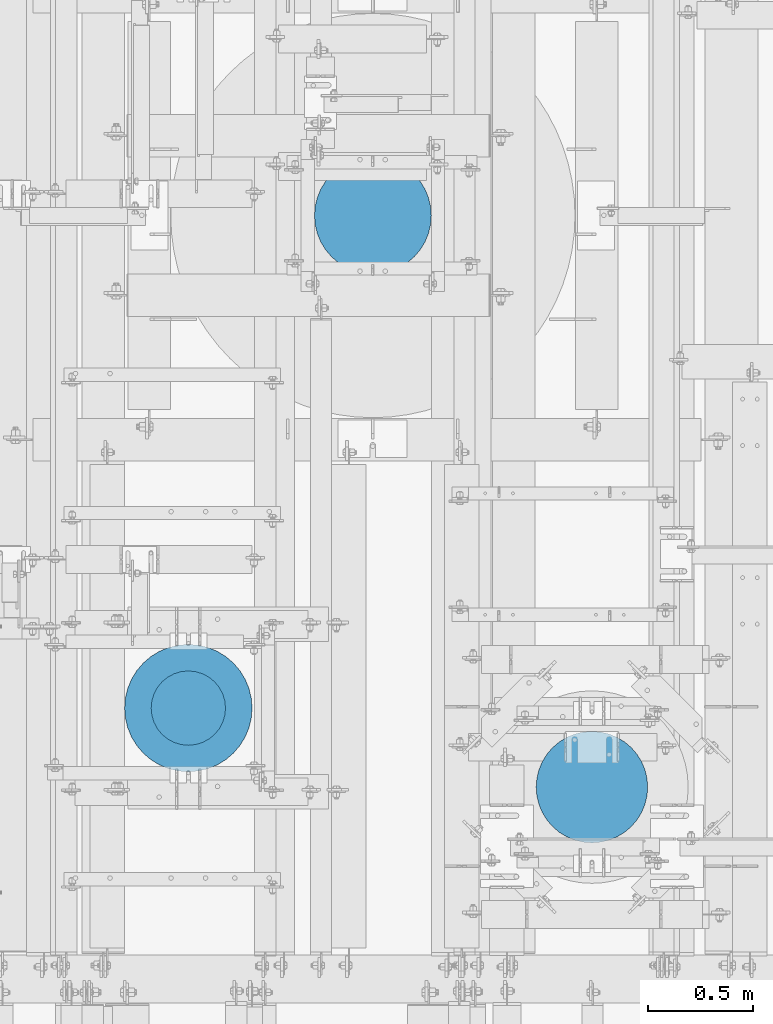
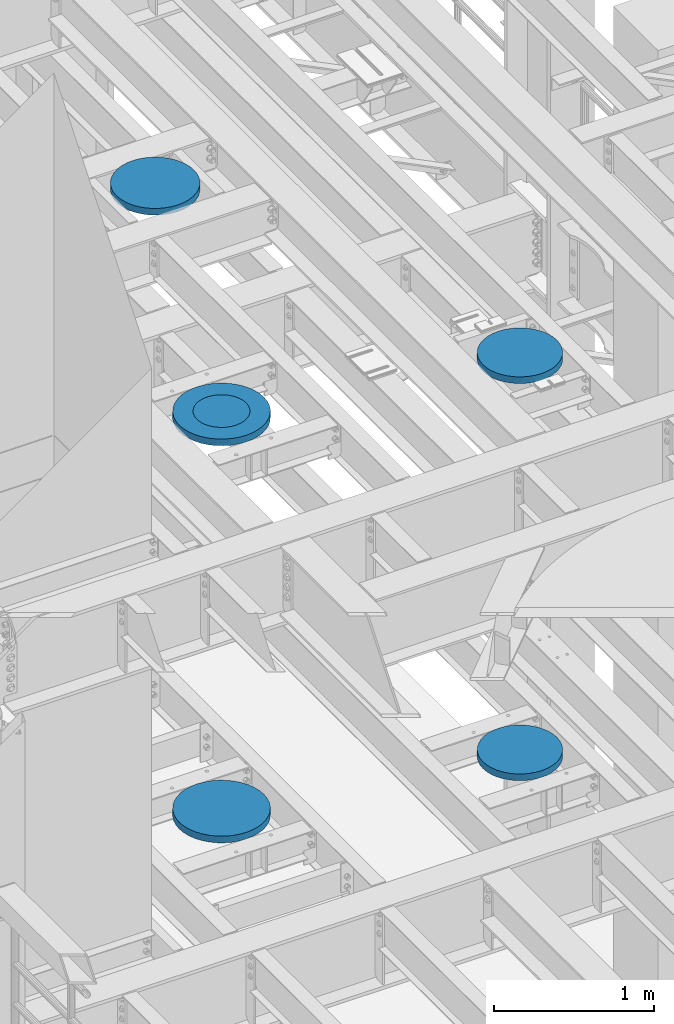
# One storey, part 840 of 1876: 6 columns, 6 elements without a shape of their own.
"""IFC2X3 building model written with IfcOpenShell, lengths in millimetres."""

import ifcopenshell
import ifcopenshell.guid

model = None  # the IFC model being written
_history = None  # IfcOwnerHistory: only IFC2X3 demands one
_inside = {}  # id of a spatial element -> (the spatial element, [elements in it])
_under = {}  # id of a project, library or spatial element -> (it, [spatial elements below it])
_declared = {}  # id of a project -> (the project, [libraries it declares])
_typed = {}  # id of a type object -> (the type object, [elements of that type])
_made_of = {}  # id of a material, layer set ... -> (it, [elements and type objects made of it])


def new_model(schema):
    """Start an empty IFC model of exactly this schema.

    Asked for "IFC4X3", IfcOpenShell would pick the latest addendum, in which some entities
    have other attributes; the version numbers below select the first issue.
    IFC2X3 requires an IfcOwnerHistory on every rooted entity: one is made here for all.
    """
    global model, _history
    if schema == "IFC4X3":
        model = ifcopenshell.file(schema_version=(4, 3, 0, 0))
    else:
        model = ifcopenshell.file(schema=schema)
    _inside.clear()
    _under.clear()
    _declared.clear()
    _typed.clear()
    _made_of.clear()
    _history = None
    if model.schema == "IFC2X3":
        org = make("IfcOrganization", Name="unknown")
        user = make(
            "IfcPersonAndOrganization",
            ThePerson=make("IfcPerson", FamilyName="unknown"),
            TheOrganization=org,
        )
        app = make(
            "IfcApplication",
            ApplicationDeveloper=org,
            Version="unknown",
            ApplicationFullName="unknown",
            ApplicationIdentifier="unknown",
        )
        _history = make(
            "IfcOwnerHistory",
            OwningUser=user,
            OwningApplication=app,
            ChangeAction="ADDED",
            CreationDate=0,
        )
    return model


def make(cls, **values):
    """One entity of the class cls with the attributes given. An attribute that is None is left unset."""
    return model.create_entity(
        cls, **{name: value for name, value in values.items() if value is not None}
    )


def rooted(cls, **values):
    """An entity with a GlobalId (a new one), such as an element, a storey or a relation."""
    return make(cls, GlobalId=ifcopenshell.guid.new(), OwnerHistory=_history, **values)


def si_unit(unit_type, name, prefix=None):
    """IfcSIUnit, for example si_unit("LENGTHUNIT", "METRE", prefix="MILLI")."""
    return make("IfcSIUnit", UnitType=unit_type, Prefix=prefix, Name=name)


def assignment(units):
    """IfcUnitAssignment: the units of a project."""
    return None if units is None else make("IfcUnitAssignment", Units=units)


def point(xyz):
    """IfcCartesianPoint."""
    return None if xyz is None else make("IfcCartesianPoint", Coordinates=xyz)


def direction(xyz):
    """IfcDirection."""
    return None if xyz is None else make("IfcDirection", DirectionRatios=xyz)


def frame(location, z_axis=None, x_axis=None):
    """IfcAxis2Placement3D, a coordinate frame: its origin and axes. An axis left out is left unset."""
    return make(
        "IfcAxis2Placement3D",
        Location=point(location),
        Axis=direction(z_axis),
        RefDirection=direction(x_axis),
    )


def origin_with_axes():
    """The frame at (0, 0, 0) with the z axis (0, 0, 1) and the x axis (1, 0, 0) written out."""
    return frame((0.0, 0.0, 0.0), z_axis=(0.0, 0.0, 1.0), x_axis=(1.0, 0.0, 0.0))


def place(relative_to, where):
    """IfcLocalPlacement: puts the frame where relative to a parent placement (None: the world)."""
    return make(
        "IfcLocalPlacement", PlacementRelTo=relative_to, RelativePlacement=where
    )


def context(
    kind, dimensions, precision=None, world=None, true_north=None, identifier=None
):
    """IfcGeometricRepresentationContext, for example the 3D "Model" context."""
    return make(
        "IfcGeometricRepresentationContext",
        ContextIdentifier=identifier,
        ContextType=kind,
        CoordinateSpaceDimension=dimensions,
        Precision=precision,
        WorldCoordinateSystem=world,
        TrueNorth=true_north,
    )


def subcontext(parent, identifier, kind, view, scale=None):
    """IfcGeometricRepresentationSubContext, for example "Body" below "Model"."""
    return make(
        "IfcGeometricRepresentationSubContext",
        ContextIdentifier=identifier,
        ContextType=kind,
        ParentContext=parent,
        TargetScale=scale,
        TargetView=view,
    )


def project(units=None, contexts=None):
    """IfcProject with its units and contexts."""
    return rooted(
        "IfcProject",
        Name="project",
        RepresentationContexts=contexts,
        UnitsInContext=assignment(units),
    )


def spatial(cls, under=None, at=None, **own):
    """A site, building, storey or space (cls), placed at a placement, below another one or the project."""
    s = rooted(cls, ObjectPlacement=at, **own)
    if under is not None:
        _under.setdefault(under.id(), (under, []))[1].append(s)
    return s


def faces_of(points, faces, orient=None, outer=None):
    """IfcFace entities. A face is a list of loops; a loop is a list of indices into points, from 0.

    orient and outer hold one flag for each loop. By default every Orientation is true, the
    first loop of a face is its IfcFaceOuterBound and the others are IfcFaceBound.
    """
    made = []
    for i, loops in enumerate(faces):
        bounds = []
        for j, loop in enumerate(loops):
            is_outer = j == 0 if outer is None else outer[i][j]
            bounds.append(
                make(
                    "IfcFaceOuterBound" if is_outer else "IfcFaceBound",
                    Bound=make("IfcPolyLoop", Polygon=[points[k] for k in loop]),
                    Orientation=True if orient is None else orient[i][j],
                )
            )
        made.append(make("IfcFace", Bounds=bounds))
    return made


def faceted_brep(points, faces, orient=None, outer=None, voids=None):
    """IfcFacetedBrep: a solid bounded by flat faces; with voids (closed shells), ...WithVoids."""
    shared = [point(p) for p in points]
    hull = make("IfcClosedShell", CfsFaces=faces_of(shared, faces, orient, outer))
    if voids is None:
        return make("IfcFacetedBrep", Outer=hull)
    return make(
        "IfcFacetedBrepWithVoids",
        Outer=hull,
        Voids=[
            make(cls, CfsFaces=faces_of(shared, fs, o, b)) for cls, fs, o, b in voids
        ],
    )


def shape(context_of_items, identifier, shape_type, items):
    """IfcShapeRepresentation: the items that make up one representation, for example the "Body"."""
    return make(
        "IfcShapeRepresentation",
        ContextOfItems=context_of_items,
        RepresentationIdentifier=identifier,
        RepresentationType=shape_type,
        Items=items,
    )


def material(Name=None, Category=None):
    """IfcMaterial."""
    return make("IfcMaterial", Name=Name, Category=Category)


def made_of(thing, what):
    """Note that an element or type object is made of a material, layer set ...; save() writes the relation."""
    if what is not None:
        _made_of.setdefault(what.id(), (what, []))[1].append(thing)
    return thing


def type_object(cls, material=None, **own):
    """A type object (cls), such as IfcWallType, which elements share."""
    return made_of(rooted(cls, **own), material)


def element(
    cls,
    number,
    at=None,
    inside=None,
    cuts=None,
    type_object=None,
    material=None,
    context=None,
    identifier="Body",
    shape_type=None,
    held_by="IfcProductDefinitionShape",
    body=None,
    shapes=None,
    **own,
):
    """One element of the class cls, such as IfcWall. Its Tag is "e" and its number.

    at: its placement. inside: the storey or other place that contains it. cuts: it is an
    opening in that element (IfcRelVoidsElement). A single representation is given by context,
    identifier, shape_type and body (its items); several are given by shapes. held_by: the class
    of the entity that holds the representations. save() writes the other relations.
    """
    e = rooted(cls, Tag="e%d" % number, ObjectPlacement=at, **own)
    if body is not None:
        shapes = [shape(context, identifier, shape_type, body)]
    if shapes is not None:
        e.Representation = make(held_by, Representations=shapes)
    if inside is not None:
        _inside.setdefault(inside.id(), (inside, []))[1].append(e)
    if cuts is not None:
        rooted(
            "IfcRelVoidsElement", RelatingBuildingElement=cuts, RelatedOpeningElement=e
        )
    if type_object is not None:
        _typed.setdefault(type_object.id(), (type_object, []))[1].append(e)
    return made_of(e, material)


def aggregate(whole, parts):
    """IfcRelAggregates: a whole, such as a stair, and the parts it consists of."""
    return rooted("IfcRelAggregates", RelatingObject=whole, RelatedObjects=parts)


def save(model, path):
    """Write the relations noted so far, then the file.

    IfcRelAggregates (storeys below a building ...), IfcRelContainedInSpatialStructure (elements
    in a storey), IfcRelDefinesByType, IfcRelAssociatesMaterial and IfcRelDeclares: one each for
    every whole, place, type object, material and project.
    """
    for whole, parts in _under.values():
        aggregate(whole, parts)
    for where, things in _inside.values():
        rooted(
            "IfcRelContainedInSpatialStructure",
            RelatedElements=things,
            RelatingStructure=where,
        )
    for kind, things in _typed.values():
        rooted("IfcRelDefinesByType", RelatedObjects=things, RelatingType=kind)
    for what, things in _made_of.values():
        rooted("IfcRelAssociatesMaterial", RelatedObjects=things, RelatingMaterial=what)
    for by, libraries in _declared.values():
        rooted("IfcRelDeclares", RelatingContext=by, RelatedDefinitions=libraries)
    model.write(path)


model = new_model("IFC2X3")

# Units and contexts
model_context = context("Model", 3, precision=1e-05, world=origin_with_axes())
body_context = subcontext(model_context, "Body", "Model", "MODEL_VIEW")
ifc_project = project(units=[si_unit("LENGTHUNIT", "METRE", prefix="MILLI"), si_unit("AREAUNIT", "SQUARE_METRE"), si_unit("VOLUMEUNIT", "CUBIC_METRE"), si_unit("MASSUNIT", "GRAM", prefix="KILO"), si_unit("TIMEUNIT", "SECOND"), si_unit("PLANEANGLEUNIT", "RADIAN"), si_unit("SOLIDANGLEUNIT", "STERADIAN"), si_unit("THERMODYNAMICTEMPERATUREUNIT", "DEGREE_CELSIUS"), si_unit("LUMINOUSINTENSITYUNIT", "LUMEN")], contexts=[model_context])

# Site, building, storey
site_placement = place(None, origin_with_axes())
site = spatial("IfcSite", under=ifc_project, at=site_placement, CompositionType="ELEMENT")
building_placement = place(site_placement, origin_with_axes())
building = spatial("IfcBuilding", under=site, at=building_placement, Name="Undefined", CompositionType="ELEMENT")
storey_placement = place(building_placement, origin_with_axes())
storey = spatial("IfcBuildingStorey", under=building, at=storey_placement, Name="Undefined", CompositionType="ELEMENT", Elevation=0.0)

# Assembly, column
assembly_1_placement = place(storey_placement, origin_with_axes())
assembly_1 = element("IfcElementAssembly", 1, at=assembly_1_placement, inside=storey, Name="COLUMN", AssemblyPlace="NOTDEFINED", PredefinedType="REINFORCEMENT_UNIT")
ifc_material = material(Name="CONCRETE/3000")
column_type_1 = type_object("IfcColumnType", PredefinedType="NOTDEFINED")
column_1_placement = place(assembly_1_placement, frame((2489.2, 2819.4, 8128.0), z_axis=(-1.0, 0.0, 0.0), x_axis=(0.0, 0.0, 1.0)))
column_1 = element("IfcColumn", 2, at=column_1_placement, type_object=column_type_1, material=ifc_material, Name="COLUMN", context=body_context, shape_type="Brep", body=[
    faceted_brep([(0.0, -177.8, 0.0), (0.0, -174.383622855695, -34.6870592544674), (50.7999999999993, -174.383622855695, -34.6870592544674), (50.7999999999993, -177.8, 0.0), (0.0, -164.265780880507, -68.0411142745133), (50.7999999999993, -164.265780880507, -68.0411142745133), (0.0, -147.835297067392, -98.7803874308856), (50.7999999999993, -147.835297067392, -98.7803874308856), (0.0, -125.723585694968, -125.723585694968), (50.7999999999993, -125.723585694968, -125.723585694968), (0.0, -98.7803874308856, -147.835297067392), (50.7999999999993, -98.7803874308856, -147.835297067392), (0.0, -68.0411142745133, -164.265780880507), (50.7999999999993, -68.0411142745133, -164.265780880507), (0.0, -34.6870592544674, -174.383622855695), (50.7999999999993, -34.6870592544674, -174.383622855695), (0.0, 0.0, -177.800003051758), (50.7999999999993, 0.0, -177.8), (0.0, 34.6870592544674, -174.383622855695), (50.7999999999993, 34.6870592544674, -174.383622855695), (0.0, 68.0411142745133, -164.265780880507), (50.7999999999993, 68.0411142745133, -164.265780880507), (0.0, 98.7803874308856, -147.835297067392), (50.7999999999993, 98.7803874308856, -147.835297067392), (0.0, 125.723585694968, -125.723585694968), (50.7999999999993, 125.723585694968, -125.723585694968), (0.0, 147.835297067392, -98.7803874308856), (50.7999999999993, 147.835297067392, -98.7803874308856), (0.0, 164.265780880507, -68.0411142745133), (50.7999999999993, 164.265780880507, -68.0411142745133), (0.0, 174.383622855694, -34.6870592544674), (50.7999999999993, 174.383622855694, -34.6870592544674), (0.0, 177.8, 0.0), (50.7999999999993, 177.8, 0.0), (0.0, 174.383622855694, 34.6870592544674), (50.7999999999993, 174.383622855694, 34.6870592544674), (0.0, 164.265780880507, 68.0411142745133), (50.7999999999993, 164.265780880507, 68.0411142745133), (0.0, 147.835297067392, 98.7803874308856), (50.7999999999993, 147.835297067392, 98.7803874308856), (0.0, 125.723585694968, 125.723585694968), (50.7999999999993, 125.723585694968, 125.723585694968), (0.0, 98.7803874308856, 147.835297067392), (50.7999999999993, 98.7803874308856, 147.835297067392), (0.0, 68.0411142745133, 164.265780880507), (50.7999999999993, 68.0411142745133, 164.265780880507), (0.0, 34.6870592544674, 174.383622855695), (50.7999999999993, 34.6870592544674, 174.383622855695), (0.0, 0.0, 177.800003051758), (50.7999999999993, 0.0, 177.8), (0.0, -34.6870592544674, 174.383622855695), (50.7999999999993, -34.6870592544674, 174.383622855695), (0.0, -68.0411142745133, 164.265780880507), (50.7999999999993, -68.0411142745133, 164.265780880507), (0.0, -98.7803874308856, 147.835297067392), (50.7999999999993, -98.7803874308856, 147.835297067392), (0.0, -125.723585694968, 125.723585694968), (50.7999999999993, -125.723585694968, 125.723585694968), (0.0, -147.835297067392, 98.7803874308856), (50.7999999999993, -147.835297067392, 98.7803874308856), (0.0, -164.265780880507, 68.0411142745133), (50.7999999999993, -164.265780880507, 68.0411142745133), (0.0, -174.383622855695, 34.6870592544674), (50.7999999999993, -174.383622855695, 34.6870592544674)], [[[0, 1, 2, 3]], [[1, 4, 5, 2]], [[4, 6, 7, 5]], [[6, 8, 9, 7]], [[8, 10, 11, 9]], [[10, 12, 13, 11]], [[12, 14, 15, 13]], [[14, 16, 17, 15]], [[16, 18, 19, 17]], [[18, 20, 21, 19]], [[20, 22, 23, 21]], [[22, 24, 25, 23]], [[24, 26, 27, 25]], [[26, 28, 29, 27]], [[28, 30, 31, 29]], [[30, 32, 33, 31]], [[32, 34, 35, 33]], [[34, 36, 37, 35]], [[36, 38, 39, 37]], [[38, 40, 41, 39]], [[40, 42, 43, 41]], [[42, 44, 45, 43]], [[44, 46, 47, 45]], [[46, 48, 49, 47]], [[48, 50, 51, 49]], [[50, 52, 53, 51]], [[52, 54, 55, 53]], [[54, 56, 57, 55]], [[56, 58, 59, 57]], [[58, 60, 61, 59]], [[60, 62, 63, 61]], [[62, 0, 3, 63]], [[5, 7, 9, 11, 13, 15, 17, 19, 21, 23, 25, 27, 29, 31, 33, 35, 37, 39, 41, 43, 45, 47, 49, 51, 53, 55, 57, 59, 61, 63, 3, 2]], [[62, 60, 58, 56, 54, 52, 50, 48, 46, 44, 42, 40, 38, 36, 34, 32, 30, 28, 26, 24, 22, 20, 18, 16, 14, 12, 10, 8, 6, 4, 1, 0]]]),
])
aggregate(assembly_1, [column_1])

assembly_2_placement = place(storey_placement, origin_with_axes())
assembly_2 = element("IfcElementAssembly", 3, at=assembly_2_placement, inside=storey, Name="COLUMN", AssemblyPlace="NOTDEFINED", PredefinedType="REINFORCEMENT_UNIT")
column_type_2 = type_object("IfcColumnType", PredefinedType="NOTDEFINED")
column_2_placement = place(assembly_2_placement, frame((2489.2, 2819.4, 8128.0), z_axis=(-1.0, 0.0, 0.0), x_axis=(0.0, 0.0, 1.0)))
column_2 = element("IfcColumn", 4, at=column_2_placement, type_object=column_type_2, material=ifc_material, Name="COLUMN", context=body_context, shape_type="Brep", body=[
    faceted_brep([(0.0, -304.8, 0.0), (0.0, -301.047406213398, -47.6812249442623), (50.7999999999993, -301.047406213398, -47.6812249442623), (50.7999999999993, -304.8, 0.0), (0.0, -289.882026166763, -94.1883798854842), (50.7999999999993, -289.882026166763, -94.1883798854842), (0.0, -271.578788572614, -138.376304320614), (50.7999999999993, -271.578788572614, -138.376304320614), (0.0, -246.588379885484, -179.156944898746), (50.7999999999993, -246.588379885484, -179.156944898746), (0.0, -215.52614690566, -215.52614690566), (50.7999999999993, -215.52614690566, -215.52614690566), (0.0, -179.156944898746, -246.588379885484), (50.7999999999993, -179.156944898746, -246.588379885484), (0.0, -138.376304320614, -271.578788572614), (50.7999999999993, -138.376304320614, -271.578788572614), (0.0, -94.1883798854838, -289.882026166763), (50.7999999999993, -94.1883798854838, -289.882026166763), (0.0, -47.6812249442623, -301.047406213398), (50.7999999999993, -47.6812249442623, -301.047406213398), (0.0, 0.0, -304.8), (50.7999999999993, 0.0, -304.8), (0.0, 47.6812249442623, -301.047406213398), (50.7999999999993, 47.6812249442623, -301.047406213398), (0.0, 94.1883798854842, -289.882026166763), (50.7999999999993, 94.1883798854842, -289.882026166763), (0.0, 138.376304320614, -271.578788572614), (50.7999999999993, 138.376304320614, -271.578788572614), (0.0, 179.156944898746, -246.588379885484), (50.7999999999993, 179.156944898746, -246.588379885484), (0.0, 215.52614690566, -215.52614690566), (50.7999999999993, 215.52614690566, -215.52614690566), (0.0, 246.588379885484, -179.156944898746), (50.7999999999993, 246.588379885484, -179.156944898746), (0.0, 271.578788572614, -138.376304320614), (50.7999999999993, 271.578788572614, -138.376304320614), (0.0, 289.882026166763, -94.1883798854838), (50.7999999999993, 289.882026166763, -94.1883798854838), (0.0, 301.047406213398, -47.6812249442623), (50.7999999999993, 301.047406213398, -47.6812249442623), (0.0, 304.8, 0.0), (50.7999999999993, 304.8, 0.0), (0.0, 301.047406213398, 47.6812249442623), (50.7999999999993, 301.047406213398, 47.6812249442623), (0.0, 289.882026166763, 94.1883798854842), (50.7999999999993, 289.882026166763, 94.1883798854842), (0.0, 271.578788572614, 138.376304320614), (50.7999999999993, 271.578788572614, 138.376304320614), (0.0, 246.588379885484, 179.156944898746), (50.7999999999993, 246.588379885484, 179.156944898746), (0.0, 215.52614690566, 215.52614690566), (50.7999999999993, 215.52614690566, 215.52614690566), (0.0, 179.156944898746, 246.588379885484), (50.7999999999993, 179.156944898746, 246.588379885484), (0.0, 138.376304320614, 271.578788572614), (50.7999999999993, 138.376304320614, 271.578788572614), (0.0, 94.1883798854838, 289.882026166763), (50.7999999999993, 94.1883798854838, 289.882026166763), (0.0, 47.6812249442623, 301.047406213398), (50.7999999999993, 47.6812249442623, 301.047406213398), (0.0, 0.0, 304.8), (50.7999999999993, 0.0, 304.8), (0.0, -47.6812249442623, 301.047406213398), (50.7999999999993, -47.6812249442623, 301.047406213398), (0.0, -94.1883798854838, 289.882026166763), (50.7999999999993, -94.1883798854838, 289.882026166763), (0.0, -138.376304320614, 271.578788572614), (50.7999999999993, -138.376304320614, 271.578788572614), (0.0, -179.156944898746, 246.588379885484), (50.7999999999993, -179.156944898746, 246.588379885484), (0.0, -215.52614690566, 215.52614690566), (50.7999999999993, -215.52614690566, 215.52614690566), (0.0, -246.588379885484, 179.156944898746), (50.7999999999993, -246.588379885484, 179.156944898746), (0.0, -271.578788572614, 138.376304320614), (50.7999999999993, -271.578788572614, 138.376304320614), (0.0, -289.882026166763, 94.1883798854838), (50.7999999999993, -289.882026166763, 94.1883798854838), (0.0, -301.047406213398, 47.6812249442623), (50.7999999999993, -301.047406213398, 47.6812249442623)], [[[0, 1, 2, 3]], [[1, 4, 5, 2]], [[4, 6, 7, 5]], [[6, 8, 9, 7]], [[8, 10, 11, 9]], [[10, 12, 13, 11]], [[12, 14, 15, 13]], [[14, 16, 17, 15]], [[16, 18, 19, 17]], [[18, 20, 21, 19]], [[20, 22, 23, 21]], [[22, 24, 25, 23]], [[24, 26, 27, 25]], [[26, 28, 29, 27]], [[28, 30, 31, 29]], [[30, 32, 33, 31]], [[32, 34, 35, 33]], [[34, 36, 37, 35]], [[36, 38, 39, 37]], [[38, 40, 41, 39]], [[40, 42, 43, 41]], [[42, 44, 45, 43]], [[44, 46, 47, 45]], [[46, 48, 49, 47]], [[48, 50, 51, 49]], [[50, 52, 53, 51]], [[52, 54, 55, 53]], [[54, 56, 57, 55]], [[56, 58, 59, 57]], [[58, 60, 61, 59]], [[60, 62, 63, 61]], [[62, 64, 65, 63]], [[64, 66, 67, 65]], [[66, 68, 69, 67]], [[68, 70, 71, 69]], [[70, 72, 73, 71]], [[72, 74, 75, 73]], [[74, 76, 77, 75]], [[76, 78, 79, 77]], [[78, 0, 3, 79]], [[5, 7, 9, 11, 13, 15, 17, 19, 21, 23, 25, 27, 29, 31, 33, 35, 37, 39, 41, 43, 45, 47, 49, 51, 53, 55, 57, 59, 61, 63, 65, 67, 69, 71, 73, 75, 77, 79, 3, 2]], [[78, 76, 74, 72, 70, 68, 66, 64, 62, 60, 58, 56, 54, 52, 50, 48, 46, 44, 42, 40, 38, 36, 34, 32, 30, 28, 26, 24, 22, 20, 18, 16, 14, 12, 10, 8, 6, 4, 1, 0]]]),
])
aggregate(assembly_2, [column_2])

assembly_3_placement = place(storey_placement, origin_with_axes())
assembly_3 = element("IfcElementAssembly", 5, at=assembly_3_placement, inside=storey, Name="COLUMN", AssemblyPlace="NOTDEFINED", PredefinedType="REINFORCEMENT_UNIT")
column_3_placement = place(assembly_3_placement, frame((2489.2, 2819.4, 5105.4), z_axis=(-1.0, 0.0, 0.0), x_axis=(0.0, 0.0, 1.0)))
column_3 = element("IfcColumn", 6, at=column_3_placement, type_object=column_type_2, material=ifc_material, Name="COLUMN", context=body_context, shape_type="Brep", body=[
    faceted_brep([(0.0, -304.8, 0.0), (0.0, -301.047406213398, -47.6812249442623), (50.7999999999993, -301.047406213398, -47.6812249442623), (50.7999999999993, -304.8, 0.0), (0.0, -289.882026166763, -94.1883798854842), (50.7999999999993, -289.882026166763, -94.1883798854842), (0.0, -271.578788572614, -138.376304320614), (50.7999999999993, -271.578788572614, -138.376304320614), (0.0, -246.588379885484, -179.156944898746), (50.7999999999993, -246.588379885484, -179.156944898746), (0.0, -215.52614690566, -215.52614690566), (50.7999999999993, -215.52614690566, -215.52614690566), (0.0, -179.156944898746, -246.588379885484), (50.7999999999993, -179.156944898746, -246.588379885484), (0.0, -138.376304320614, -271.578788572614), (50.7999999999993, -138.376304320614, -271.578788572614), (0.0, -94.1883798854838, -289.882026166763), (50.7999999999993, -94.1883798854838, -289.882026166763), (0.0, -47.6812249442623, -301.047406213398), (50.7999999999993, -47.6812249442623, -301.047406213398), (0.0, 0.0, -304.8), (50.7999999999993, 0.0, -304.8), (0.0, 47.6812249442623, -301.047406213398), (50.7999999999993, 47.6812249442623, -301.047406213398), (0.0, 94.1883798854842, -289.882026166763), (50.7999999999993, 94.1883798854842, -289.882026166763), (0.0, 138.376304320614, -271.578788572614), (50.7999999999993, 138.376304320614, -271.578788572614), (0.0, 179.156944898746, -246.588379885484), (50.7999999999993, 179.156944898746, -246.588379885484), (0.0, 215.52614690566, -215.52614690566), (50.7999999999993, 215.52614690566, -215.52614690566), (0.0, 246.588379885484, -179.156944898746), (50.7999999999993, 246.588379885484, -179.156944898746), (0.0, 271.578788572614, -138.376304320614), (50.7999999999993, 271.578788572614, -138.376304320614), (0.0, 289.882026166763, -94.1883798854838), (50.7999999999993, 289.882026166763, -94.1883798854838), (0.0, 301.047406213398, -47.6812249442623), (50.7999999999993, 301.047406213398, -47.6812249442623), (0.0, 304.8, 0.0), (50.7999999999993, 304.8, 0.0), (0.0, 301.047406213398, 47.6812249442623), (50.7999999999993, 301.047406213398, 47.6812249442623), (0.0, 289.882026166763, 94.1883798854842), (50.7999999999993, 289.882026166763, 94.1883798854842), (0.0, 271.578788572614, 138.376304320614), (50.7999999999993, 271.578788572614, 138.376304320614), (0.0, 246.588379885484, 179.156944898746), (50.7999999999993, 246.588379885484, 179.156944898746), (0.0, 215.52614690566, 215.52614690566), (50.7999999999993, 215.52614690566, 215.52614690566), (0.0, 179.156944898746, 246.588379885484), (50.7999999999993, 179.156944898746, 246.588379885484), (0.0, 138.376304320614, 271.578788572614), (50.7999999999993, 138.376304320614, 271.578788572614), (0.0, 94.1883798854838, 289.882026166763), (50.7999999999993, 94.1883798854838, 289.882026166763), (0.0, 47.6812249442623, 301.047406213398), (50.7999999999993, 47.6812249442623, 301.047406213398), (0.0, 0.0, 304.8), (50.7999999999993, 0.0, 304.8), (0.0, -47.6812249442623, 301.047406213398), (50.7999999999993, -47.6812249442623, 301.047406213398), (0.0, -94.1883798854838, 289.882026166763), (50.7999999999993, -94.1883798854838, 289.882026166763), (0.0, -138.376304320614, 271.578788572614), (50.7999999999993, -138.376304320614, 271.578788572614), (0.0, -179.156944898746, 246.588379885484), (50.7999999999993, -179.156944898746, 246.588379885484), (0.0, -215.52614690566, 215.52614690566), (50.7999999999993, -215.52614690566, 215.52614690566), (0.0, -246.588379885484, 179.156944898746), (50.7999999999993, -246.588379885484, 179.156944898746), (0.0, -271.578788572614, 138.376304320614), (50.7999999999993, -271.578788572614, 138.376304320614), (0.0, -289.882026166763, 94.1883798854838), (50.7999999999993, -289.882026166763, 94.1883798854838), (0.0, -301.047406213398, 47.6812249442623), (50.7999999999993, -301.047406213398, 47.6812249442623)], [[[0, 1, 2, 3]], [[1, 4, 5, 2]], [[4, 6, 7, 5]], [[6, 8, 9, 7]], [[8, 10, 11, 9]], [[10, 12, 13, 11]], [[12, 14, 15, 13]], [[14, 16, 17, 15]], [[16, 18, 19, 17]], [[18, 20, 21, 19]], [[20, 22, 23, 21]], [[22, 24, 25, 23]], [[24, 26, 27, 25]], [[26, 28, 29, 27]], [[28, 30, 31, 29]], [[30, 32, 33, 31]], [[32, 34, 35, 33]], [[34, 36, 37, 35]], [[36, 38, 39, 37]], [[38, 40, 41, 39]], [[40, 42, 43, 41]], [[42, 44, 45, 43]], [[44, 46, 47, 45]], [[46, 48, 49, 47]], [[48, 50, 51, 49]], [[50, 52, 53, 51]], [[52, 54, 55, 53]], [[54, 56, 57, 55]], [[56, 58, 59, 57]], [[58, 60, 61, 59]], [[60, 62, 63, 61]], [[62, 64, 65, 63]], [[64, 66, 67, 65]], [[66, 68, 69, 67]], [[68, 70, 71, 69]], [[70, 72, 73, 71]], [[72, 74, 75, 73]], [[74, 76, 77, 75]], [[76, 78, 79, 77]], [[78, 0, 3, 79]], [[5, 7, 9, 11, 13, 15, 17, 19, 21, 23, 25, 27, 29, 31, 33, 35, 37, 39, 41, 43, 45, 47, 49, 51, 53, 55, 57, 59, 61, 63, 65, 67, 69, 71, 73, 75, 77, 79, 3, 2]], [[78, 76, 74, 72, 70, 68, 66, 64, 62, 60, 58, 56, 54, 52, 50, 48, 46, 44, 42, 40, 38, 36, 34, 32, 30, 28, 26, 24, 22, 20, 18, 16, 14, 12, 10, 8, 6, 4, 1, 0]]]),
])
aggregate(assembly_3, [column_3])

assembly_4_placement = place(storey_placement, origin_with_axes())
assembly_4 = element("IfcElementAssembly", 7, at=assembly_4_placement, inside=storey, Name="COLUMN", AssemblyPlace="NOTDEFINED", PredefinedType="REINFORCEMENT_UNIT")
column_type_3 = type_object("IfcColumnType", PredefinedType="NOTDEFINED")
column_4_placement = place(assembly_4_placement, frame((3371.85, 5175.25, 8128.0), z_axis=(-1.0, 0.0, 0.0), x_axis=(0.0, 0.0, 1.0)))
column_4 = element("IfcColumn", 8, at=column_4_placement, type_object=column_type_3, material=ifc_material, Name="COLUMN", context=body_context, shape_type="Brep", body=[
    faceted_brep([(0.0, -279.4, 0.0), (0.0, -275.960122362281, -43.7077895322406), (50.7999999999993, -275.960122362281, -43.7077895322406), (50.7999999999993, -279.4, 0.0), (0.0, -265.725190652865, -86.3393482283603), (50.7999999999993, -265.725190652865, -86.3393482283603), (0.0, -248.947222858231, -126.844945627229), (50.7999999999993, -248.947222858231, -126.844945627229), (0.0, -226.03934822836, -164.227199490517), (50.7999999999993, -226.03934822836, -164.227199490517), (0.0, -197.565634663521, -197.565634663521), (50.7999999999993, -197.565634663521, -197.565634663521), (0.0, -164.227199490517, -226.03934822836), (50.7999999999993, -164.227199490517, -226.03934822836), (0.0, -126.84494562723, -248.94722285823), (50.7999999999993, -126.84494562723, -248.94722285823), (0.0, -86.3393482283609, -265.725190652866), (50.7999999999993, -86.3393482283609, -265.725190652866), (0.0, -43.70778953224, -275.960122362281), (50.7999999999993, -43.70778953224, -275.960122362281), (0.0, 0.0, -279.4), (50.7999999999993, 0.0, -279.4), (0.0, 43.70778953224, -275.960122362281), (50.7999999999993, 43.70778953224, -275.960122362281), (0.0, 86.3393482283609, -265.725190652866), (50.7999999999993, 86.3393482283609, -265.725190652866), (0.0, 126.84494562723, -248.94722285823), (50.7999999999993, 126.84494562723, -248.94722285823), (0.0, 164.227199490517, -226.03934822836), (50.7999999999993, 164.227199490517, -226.03934822836), (0.0, 197.565634663521, -197.565634663521), (50.7999999999993, 197.565634663521, -197.565634663521), (0.0, 226.03934822836, -164.227199490517), (50.7999999999993, 226.03934822836, -164.227199490517), (0.0, 248.947222858231, -126.844945627229), (50.7999999999993, 248.947222858231, -126.844945627229), (0.0, 265.725190652865, -86.3393482283602), (50.7999999999993, 265.725190652865, -86.3393482283602), (0.0, 275.960122362281, -43.7077895322404), (50.7999999999993, 275.960122362281, -43.7077895322404), (0.0, 279.4, 5.6843418860808e-14), (50.7999999999993, 279.4, 5.6843418860808e-14), (0.0, 275.960122362281, 43.7077895322406), (50.7999999999993, 275.960122362281, 43.7077895322406), (0.0, 265.725190652865, 86.3393482283603), (50.7999999999993, 265.725190652865, 86.3393482283603), (0.0, 248.947222858231, 126.844945627229), (50.7999999999993, 248.947222858231, 126.844945627229), (0.0, 226.03934822836, 164.227199490517), (50.7999999999993, 226.03934822836, 164.227199490517), (0.0, 197.565634663521, 197.565634663521), (50.7999999999993, 197.565634663521, 197.565634663521), (0.0, 164.227199490517, 226.03934822836), (50.7999999999993, 164.227199490517, 226.03934822836), (0.0, 126.84494562723, 248.94722285823), (50.7999999999993, 126.84494562723, 248.94722285823), (0.0, 86.3393482283609, 265.725190652866), (50.7999999999993, 86.3393482283609, 265.725190652866), (0.0, 43.70778953224, 275.960122362281), (50.7999999999993, 43.70778953224, 275.960122362281), (0.0, 0.0, 279.4), (50.7999999999993, 0.0, 279.4), (0.0, -43.70778953224, 275.960122362281), (50.7999999999993, -43.70778953224, 275.960122362281), (0.0, -86.3393482283609, 265.725190652866), (50.7999999999993, -86.3393482283609, 265.725190652866), (0.0, -126.84494562723, 248.94722285823), (50.7999999999993, -126.84494562723, 248.94722285823), (0.0, -164.227199490517, 226.03934822836), (50.7999999999993, -164.227199490517, 226.03934822836), (0.0, -197.565634663521, 197.565634663521), (50.7999999999993, -197.565634663521, 197.565634663521), (0.0, -226.03934822836, 164.227199490517), (50.7999999999993, -226.03934822836, 164.227199490517), (0.0, -248.947222858231, 126.844945627229), (50.7999999999993, -248.947222858231, 126.844945627229), (0.0, -265.725190652865, 86.3393482283603), (50.7999999999993, -265.725190652865, 86.3393482283603), (0.0, -275.960122362281, 43.7077895322405), (50.7999999999993, -275.960122362281, 43.7077895322405)], [[[0, 1, 2, 3]], [[1, 4, 5, 2]], [[4, 6, 7, 5]], [[6, 8, 9, 7]], [[8, 10, 11, 9]], [[10, 12, 13, 11]], [[12, 14, 15, 13]], [[14, 16, 17, 15]], [[16, 18, 19, 17]], [[18, 20, 21, 19]], [[20, 22, 23, 21]], [[22, 24, 25, 23]], [[24, 26, 27, 25]], [[26, 28, 29, 27]], [[28, 30, 31, 29]], [[30, 32, 33, 31]], [[32, 34, 35, 33]], [[34, 36, 37, 35]], [[36, 38, 39, 37]], [[38, 40, 41, 39]], [[40, 42, 43, 41]], [[42, 44, 45, 43]], [[44, 46, 47, 45]], [[46, 48, 49, 47]], [[48, 50, 51, 49]], [[50, 52, 53, 51]], [[52, 54, 55, 53]], [[54, 56, 57, 55]], [[56, 58, 59, 57]], [[58, 60, 61, 59]], [[60, 62, 63, 61]], [[62, 64, 65, 63]], [[64, 66, 67, 65]], [[66, 68, 69, 67]], [[68, 70, 71, 69]], [[70, 72, 73, 71]], [[72, 74, 75, 73]], [[74, 76, 77, 75]], [[76, 78, 79, 77]], [[78, 0, 3, 79]], [[5, 7, 9, 11, 13, 15, 17, 19, 21, 23, 25, 27, 29, 31, 33, 35, 37, 39, 41, 43, 45, 47, 49, 51, 53, 55, 57, 59, 61, 63, 65, 67, 69, 71, 73, 75, 77, 79, 3, 2]], [[78, 76, 74, 72, 70, 68, 66, 64, 62, 60, 58, 56, 54, 52, 50, 48, 46, 44, 42, 40, 38, 36, 34, 32, 30, 28, 26, 24, 22, 20, 18, 16, 14, 12, 10, 8, 6, 4, 1, 0]]]),
])
aggregate(assembly_4, [column_4])

assembly_5_placement = place(storey_placement, origin_with_axes())
assembly_5 = element("IfcElementAssembly", 9, at=assembly_5_placement, inside=storey, Name="COLUMN", AssemblyPlace="NOTDEFINED", PredefinedType="REINFORCEMENT_UNIT")
column_type_4 = type_object("IfcColumnType", PredefinedType="NOTDEFINED")
column_5_placement = place(assembly_5_placement, frame((4419.6, 2441.575, 8128.0), z_axis=(-1.0, 0.0, 0.0), x_axis=(0.0, 0.0, 1.0)))
column_5 = element("IfcColumn", 10, at=column_5_placement, type_object=column_type_4, material=ifc_material, Name="COLUMN", context=body_context, shape_type="Brep", body=[
    faceted_brep([(0.0, -266.7, 0.0), (0.0, -263.416480436723, -41.7210718262295), (50.7999999999993, -263.416480436723, -41.7210718262295), (50.7999999999993, -266.7, 0.0), (0.0, -253.646772895917, -82.4148323997988), (50.7999999999993, -253.646772895917, -82.4148323997988), (0.0, -237.631440001038, -121.079266280537), (50.7999999999993, -237.631440001038, -121.079266280537), (0.0, -215.764832399798, -156.762326786403), (50.7999999999993, -215.764832399798, -156.762326786403), (0.0, -188.585378542452, -188.585378542452), (50.7999999999993, -188.585378542452, -188.585378542452), (0.0, -156.762326786402, -215.764832399798), (50.7999999999993, -156.762326786402, -215.764832399798), (0.0, -121.079266280537, -237.631440001038), (50.7999999999993, -121.079266280537, -237.631440001038), (0.0, -82.4148323997983, -253.646772895918), (50.7999999999993, -82.4148323997983, -253.646772895918), (0.0, -41.7210718262295, -263.416480436723), (50.7999999999993, -41.7210718262295, -263.416480436723), (0.0, 0.0, -266.7), (50.7999999999993, 0.0, -266.7), (0.0, 41.7210718262295, -263.416480436723), (50.7999999999993, 41.7210718262295, -263.416480436723), (0.0, 82.4148323997983, -253.646772895918), (50.7999999999993, 82.4148323997983, -253.646772895918), (0.0, 121.079266280537, -237.631440001038), (50.7999999999993, 121.079266280537, -237.631440001038), (0.0, 156.762326786403, -215.764832399798), (50.7999999999993, 156.762326786403, -215.764832399798), (0.0, 188.585378542452, -188.585378542452), (50.7999999999993, 188.585378542452, -188.585378542452), (0.0, 215.764832399798, -156.762326786403), (50.7999999999993, 215.764832399798, -156.762326786403), (0.0, 237.631440001038, -121.079266280537), (50.7999999999993, 237.631440001038, -121.079266280537), (0.0, 253.646772895917, -82.4148323997988), (50.7999999999993, 253.646772895917, -82.4148323997988), (0.0, 263.416480436723, -41.7210718262295), (50.7999999999993, 263.416480436723, -41.7210718262295), (0.0, 266.7, 0.0), (50.7999999999993, 266.7, 0.0), (0.0, 263.416480436723, 41.7210718262295), (50.7999999999993, 263.416480436723, 41.7210718262295), (0.0, 253.646772895917, 82.4148323997988), (50.7999999999993, 253.646772895917, 82.4148323997988), (0.0, 237.631440001038, 121.079266280537), (50.7999999999993, 237.631440001038, 121.079266280537), (0.0, 215.764832399798, 156.762326786403), (50.7999999999993, 215.764832399798, 156.762326786403), (0.0, 188.585378542452, 188.585378542452), (50.7999999999993, 188.585378542452, 188.585378542452), (0.0, 156.762326786402, 215.764832399798), (50.7999999999993, 156.762326786402, 215.764832399798), (0.0, 121.079266280537, 237.631440001038), (50.7999999999993, 121.079266280537, 237.631440001038), (0.0, 82.4148323997983, 253.646772895918), (50.7999999999993, 82.4148323997983, 253.646772895918), (0.0, 41.7210718262295, 263.416480436723), (50.7999999999993, 41.7210718262295, 263.416480436723), (0.0, 0.0, 266.7), (50.7999999999993, 0.0, 266.7), (0.0, -41.7210718262295, 263.416480436723), (50.7999999999993, -41.7210718262295, 263.416480436723), (0.0, -82.4148323997983, 253.646772895918), (50.7999999999993, -82.4148323997983, 253.646772895918), (0.0, -121.079266280537, 237.631440001038), (50.7999999999993, -121.079266280537, 237.631440001038), (0.0, -156.762326786403, 215.764832399798), (50.7999999999993, -156.762326786403, 215.764832399798), (0.0, -188.585378542452, 188.585378542452), (50.7999999999993, -188.585378542452, 188.585378542452), (0.0, -215.764832399798, 156.762326786403), (50.7999999999993, -215.764832399798, 156.762326786403), (0.0, -237.631440001038, 121.079266280537), (50.7999999999993, -237.631440001038, 121.079266280537), (0.0, -253.646772895917, 82.4148323997988), (50.7999999999993, -253.646772895917, 82.4148323997988), (0.0, -263.416480436723, 41.7210718262295), (50.7999999999993, -263.416480436723, 41.7210718262295)], [[[0, 1, 2, 3]], [[1, 4, 5, 2]], [[4, 6, 7, 5]], [[6, 8, 9, 7]], [[8, 10, 11, 9]], [[10, 12, 13, 11]], [[12, 14, 15, 13]], [[14, 16, 17, 15]], [[16, 18, 19, 17]], [[18, 20, 21, 19]], [[20, 22, 23, 21]], [[22, 24, 25, 23]], [[24, 26, 27, 25]], [[26, 28, 29, 27]], [[28, 30, 31, 29]], [[30, 32, 33, 31]], [[32, 34, 35, 33]], [[34, 36, 37, 35]], [[36, 38, 39, 37]], [[38, 40, 41, 39]], [[40, 42, 43, 41]], [[42, 44, 45, 43]], [[44, 46, 47, 45]], [[46, 48, 49, 47]], [[48, 50, 51, 49]], [[50, 52, 53, 51]], [[52, 54, 55, 53]], [[54, 56, 57, 55]], [[56, 58, 59, 57]], [[58, 60, 61, 59]], [[60, 62, 63, 61]], [[62, 64, 65, 63]], [[64, 66, 67, 65]], [[66, 68, 69, 67]], [[68, 70, 71, 69]], [[70, 72, 73, 71]], [[72, 74, 75, 73]], [[74, 76, 77, 75]], [[76, 78, 79, 77]], [[78, 0, 3, 79]], [[5, 7, 9, 11, 13, 15, 17, 19, 21, 23, 25, 27, 29, 31, 33, 35, 37, 39, 41, 43, 45, 47, 49, 51, 53, 55, 57, 59, 61, 63, 65, 67, 69, 71, 73, 75, 77, 79, 3, 2]], [[78, 76, 74, 72, 70, 68, 66, 64, 62, 60, 58, 56, 54, 52, 50, 48, 46, 44, 42, 40, 38, 36, 34, 32, 30, 28, 26, 24, 22, 20, 18, 16, 14, 12, 10, 8, 6, 4, 1, 0]]]),
])
aggregate(assembly_5, [column_5])

assembly_6_placement = place(storey_placement, origin_with_axes())
assembly_6 = element("IfcElementAssembly", 11, at=assembly_6_placement, inside=storey, Name="COLUMN", AssemblyPlace="NOTDEFINED", PredefinedType="REINFORCEMENT_UNIT")
column_6_placement = place(assembly_6_placement, frame((4419.6, 2441.575, 5105.4), z_axis=(-1.0, 0.0, 0.0), x_axis=(0.0, 0.0, 1.0)))
column_6 = element("IfcColumn", 12, at=column_6_placement, type_object=column_type_4, material=ifc_material, Name="COLUMN", context=body_context, shape_type="Brep", body=[
    faceted_brep([(0.0, -266.7, 0.0), (0.0, -263.416480436723, -41.7210718262295), (50.7999999999993, -263.416480436723, -41.7210718262295), (50.7999999999993, -266.7, 0.0), (0.0, -253.646772895917, -82.4148323997988), (50.7999999999993, -253.646772895917, -82.4148323997988), (0.0, -237.631440001038, -121.079266280537), (50.7999999999993, -237.631440001038, -121.079266280537), (0.0, -215.764832399798, -156.762326786403), (50.7999999999993, -215.764832399798, -156.762326786403), (0.0, -188.585378542452, -188.585378542452), (50.7999999999993, -188.585378542452, -188.585378542452), (0.0, -156.762326786402, -215.764832399798), (50.7999999999993, -156.762326786402, -215.764832399798), (0.0, -121.079266280537, -237.631440001038), (50.7999999999993, -121.079266280537, -237.631440001038), (0.0, -82.4148323997983, -253.646772895918), (50.7999999999993, -82.4148323997983, -253.646772895918), (0.0, -41.7210718262295, -263.416480436723), (50.7999999999993, -41.7210718262295, -263.416480436723), (0.0, 0.0, -266.7), (50.7999999999993, 0.0, -266.7), (0.0, 41.7210718262295, -263.416480436723), (50.7999999999993, 41.7210718262295, -263.416480436723), (0.0, 82.4148323997983, -253.646772895918), (50.7999999999993, 82.4148323997983, -253.646772895918), (0.0, 121.079266280537, -237.631440001038), (50.7999999999993, 121.079266280537, -237.631440001038), (0.0, 156.762326786403, -215.764832399798), (50.7999999999993, 156.762326786403, -215.764832399798), (0.0, 188.585378542452, -188.585378542452), (50.7999999999993, 188.585378542452, -188.585378542452), (0.0, 215.764832399798, -156.762326786403), (50.7999999999993, 215.764832399798, -156.762326786403), (0.0, 237.631440001038, -121.079266280537), (50.7999999999993, 237.631440001038, -121.079266280537), (0.0, 253.646772895917, -82.4148323997988), (50.7999999999993, 253.646772895917, -82.4148323997988), (0.0, 263.416480436723, -41.7210718262295), (50.7999999999993, 263.416480436723, -41.7210718262295), (0.0, 266.7, 0.0), (50.7999999999993, 266.7, 0.0), (0.0, 263.416480436723, 41.7210718262295), (50.7999999999993, 263.416480436723, 41.7210718262295), (0.0, 253.646772895917, 82.4148323997988), (50.7999999999993, 253.646772895917, 82.4148323997988), (0.0, 237.631440001038, 121.079266280537), (50.7999999999993, 237.631440001038, 121.079266280537), (0.0, 215.764832399798, 156.762326786403), (50.7999999999993, 215.764832399798, 156.762326786403), (0.0, 188.585378542452, 188.585378542452), (50.7999999999993, 188.585378542452, 188.585378542452), (0.0, 156.762326786402, 215.764832399798), (50.7999999999993, 156.762326786402, 215.764832399798), (0.0, 121.079266280537, 237.631440001038), (50.7999999999993, 121.079266280537, 237.631440001038), (0.0, 82.4148323997983, 253.646772895918), (50.7999999999993, 82.4148323997983, 253.646772895918), (0.0, 41.7210718262295, 263.416480436723), (50.7999999999993, 41.7210718262295, 263.416480436723), (0.0, 0.0, 266.7), (50.7999999999993, 0.0, 266.7), (0.0, -41.7210718262295, 263.416480436723), (50.7999999999993, -41.7210718262295, 263.416480436723), (0.0, -82.4148323997983, 253.646772895918), (50.7999999999993, -82.4148323997983, 253.646772895918), (0.0, -121.079266280537, 237.631440001038), (50.7999999999993, -121.079266280537, 237.631440001038), (0.0, -156.762326786403, 215.764832399798), (50.7999999999993, -156.762326786403, 215.764832399798), (0.0, -188.585378542452, 188.585378542452), (50.7999999999993, -188.585378542452, 188.585378542452), (0.0, -215.764832399798, 156.762326786403), (50.7999999999993, -215.764832399798, 156.762326786403), (0.0, -237.631440001038, 121.079266280537), (50.7999999999993, -237.631440001038, 121.079266280537), (0.0, -253.646772895917, 82.4148323997988), (50.7999999999993, -253.646772895917, 82.4148323997988), (0.0, -263.416480436723, 41.7210718262295), (50.7999999999993, -263.416480436723, 41.7210718262295)], [[[0, 1, 2, 3]], [[1, 4, 5, 2]], [[4, 6, 7, 5]], [[6, 8, 9, 7]], [[8, 10, 11, 9]], [[10, 12, 13, 11]], [[12, 14, 15, 13]], [[14, 16, 17, 15]], [[16, 18, 19, 17]], [[18, 20, 21, 19]], [[20, 22, 23, 21]], [[22, 24, 25, 23]], [[24, 26, 27, 25]], [[26, 28, 29, 27]], [[28, 30, 31, 29]], [[30, 32, 33, 31]], [[32, 34, 35, 33]], [[34, 36, 37, 35]], [[36, 38, 39, 37]], [[38, 40, 41, 39]], [[40, 42, 43, 41]], [[42, 44, 45, 43]], [[44, 46, 47, 45]], [[46, 48, 49, 47]], [[48, 50, 51, 49]], [[50, 52, 53, 51]], [[52, 54, 55, 53]], [[54, 56, 57, 55]], [[56, 58, 59, 57]], [[58, 60, 61, 59]], [[60, 62, 63, 61]], [[62, 64, 65, 63]], [[64, 66, 67, 65]], [[66, 68, 69, 67]], [[68, 70, 71, 69]], [[70, 72, 73, 71]], [[72, 74, 75, 73]], [[74, 76, 77, 75]], [[76, 78, 79, 77]], [[78, 0, 3, 79]], [[5, 7, 9, 11, 13, 15, 17, 19, 21, 23, 25, 27, 29, 31, 33, 35, 37, 39, 41, 43, 45, 47, 49, 51, 53, 55, 57, 59, 61, 63, 65, 67, 69, 71, 73, 75, 77, 79, 3, 2]], [[78, 76, 74, 72, 70, 68, 66, 64, 62, 60, 58, 56, 54, 52, 50, 48, 46, 44, 42, 40, 38, 36, 34, 32, 30, 28, 26, 24, 22, 20, 18, 16, 14, 12, 10, 8, 6, 4, 1, 0]]]),
])
aggregate(assembly_6, [column_6])

save(model, "model.ifc")
